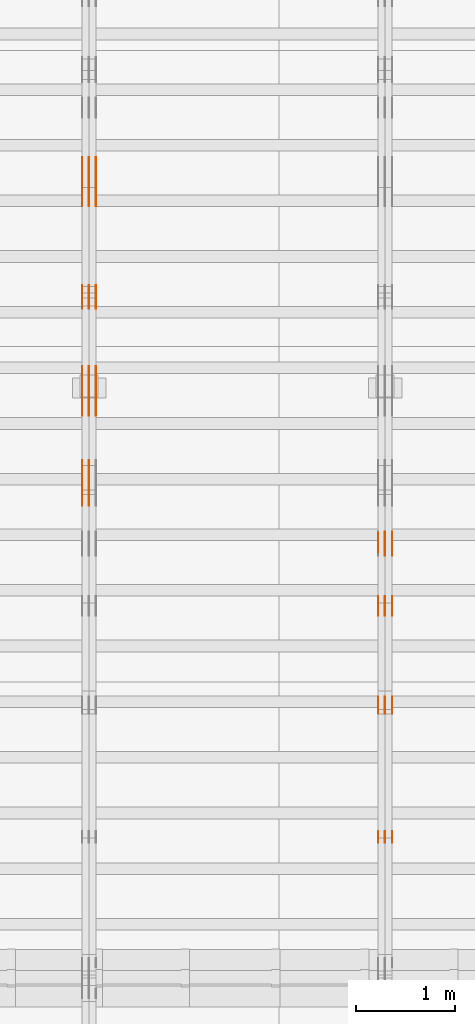
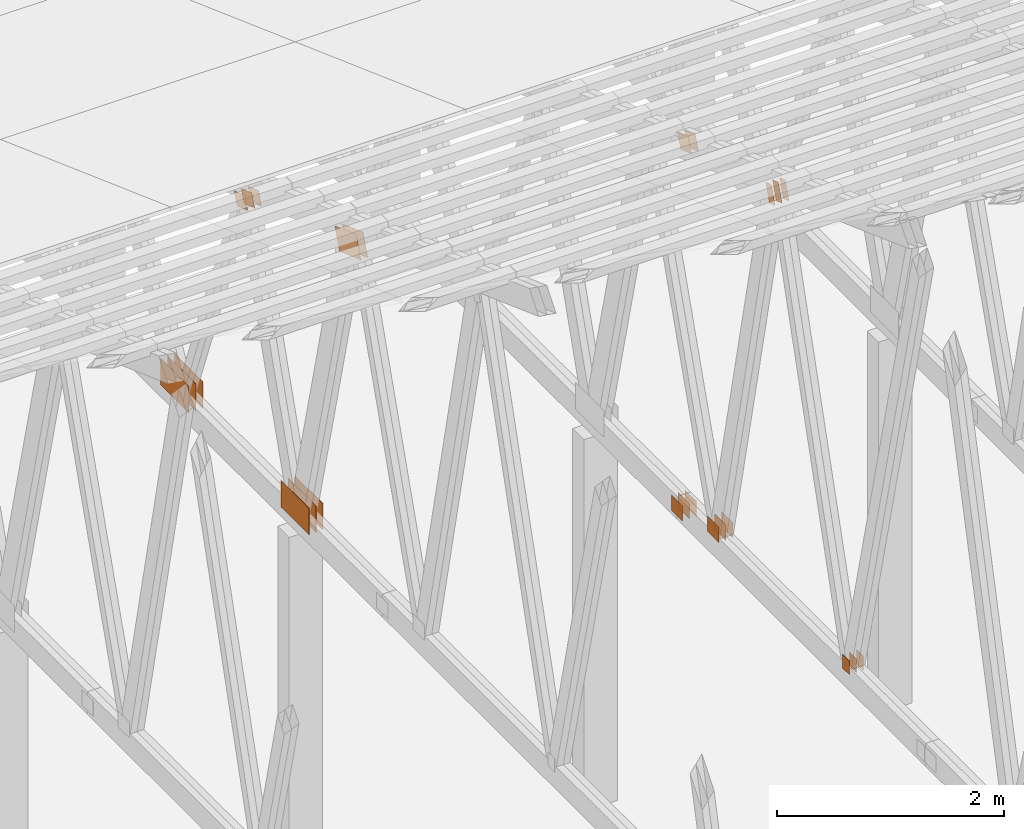
# One storey, part 122 of 189: 32 proxies.
"""IFC2X3 building model written with IfcOpenShell, lengths in millimetres."""

import ifcopenshell
import ifcopenshell.guid

model = None  # the IFC model being written
_history = None  # IfcOwnerHistory: only IFC2X3 demands one
_inside = {}  # id of a spatial element -> (the spatial element, [elements in it])
_under = {}  # id of a project, library or spatial element -> (it, [spatial elements below it])
_declared = {}  # id of a project -> (the project, [libraries it declares])
_typed = {}  # id of a type object -> (the type object, [elements of that type])
_made_of = {}  # id of a material, layer set ... -> (it, [elements and type objects made of it])


def new_model(schema):
    """Start an empty IFC model of exactly this schema.

    Asked for "IFC4X3", IfcOpenShell would pick the latest addendum, in which some entities
    have other attributes; the version numbers below select the first issue.
    IFC2X3 requires an IfcOwnerHistory on every rooted entity: one is made here for all.
    """
    global model, _history
    if schema == "IFC4X3":
        model = ifcopenshell.file(schema_version=(4, 3, 0, 0))
    else:
        model = ifcopenshell.file(schema=schema)
    _inside.clear()
    _under.clear()
    _declared.clear()
    _typed.clear()
    _made_of.clear()
    _history = None
    if model.schema == "IFC2X3":
        org = make("IfcOrganization", Name="unknown")
        user = make(
            "IfcPersonAndOrganization",
            ThePerson=make("IfcPerson", FamilyName="unknown"),
            TheOrganization=org,
        )
        app = make(
            "IfcApplication",
            ApplicationDeveloper=org,
            Version="unknown",
            ApplicationFullName="unknown",
            ApplicationIdentifier="unknown",
        )
        _history = make(
            "IfcOwnerHistory",
            OwningUser=user,
            OwningApplication=app,
            ChangeAction="ADDED",
            CreationDate=0,
        )
    return model


def make(cls, **values):
    """One entity of the class cls with the attributes given. An attribute that is None is left unset."""
    return model.create_entity(
        cls, **{name: value for name, value in values.items() if value is not None}
    )


def entity(cls, *values):
    """Any entity or typed value of the class cls, its attributes in the order of the schema. None: left unset."""
    e = model.create_entity(cls)
    for i, value in enumerate(values):
        if value is not None:
            e[i] = value
    return e


def rooted(cls, **values):
    """An entity with a GlobalId (a new one), such as an element, a storey or a relation."""
    return make(cls, GlobalId=ifcopenshell.guid.new(), OwnerHistory=_history, **values)


def si_unit(unit_type, name, prefix=None):
    """IfcSIUnit, for example si_unit("LENGTHUNIT", "METRE", prefix="MILLI")."""
    return make("IfcSIUnit", UnitType=unit_type, Prefix=prefix, Name=name)


def converted_unit(unit_type, name, factor, base, dimensions=None, offset=None):
    """IfcConversionBasedUnit, such as the inch: factor (a typed value) times the base unit."""
    return make(
        "IfcConversionBasedUnit"
        if offset is None
        else "IfcConversionBasedUnitWithOffset",
        ConversionOffset=offset,
        Dimensions=None
        if dimensions is None
        else entity("IfcDimensionalExponents", *dimensions),
        UnitType=unit_type,
        Name=name,
        ConversionFactor=make(
            "IfcMeasureWithUnit", ValueComponent=factor, UnitComponent=base
        ),
    )


def derived_unit(unit_type, elements):
    """IfcDerivedUnit: a product of units, each with its exponent."""
    return make(
        "IfcDerivedUnit",
        Elements=[
            make("IfcDerivedUnitElement", Unit=unit, Exponent=power)
            for unit, power in elements
        ],
        UnitType=unit_type,
    )


def assignment(units):
    """IfcUnitAssignment: the units of a project."""
    return None if units is None else make("IfcUnitAssignment", Units=units)


def point(xyz):
    """IfcCartesianPoint."""
    return None if xyz is None else make("IfcCartesianPoint", Coordinates=xyz)


def direction(xyz):
    """IfcDirection."""
    return None if xyz is None else make("IfcDirection", DirectionRatios=xyz)


def frame(location, z_axis=None, x_axis=None):
    """IfcAxis2Placement3D, a coordinate frame: its origin and axes. An axis left out is left unset."""
    return make(
        "IfcAxis2Placement3D",
        Location=point(location),
        Axis=direction(z_axis),
        RefDirection=direction(x_axis),
    )


def frame_2d(location, x_axis=None):
    """IfcAxis2Placement2D, a coordinate frame in the plane: its origin and x axis."""
    return make(
        "IfcAxis2Placement2D", Location=point(location), RefDirection=direction(x_axis)
    )


def origin():
    """The frame at (0, 0, 0) with its axes left unset."""
    return frame((0.0, 0.0, 0.0))


def origin_2d_with_axis():
    """The frame at (0, 0) in the plane with the x axis (1, 0) written out."""
    return frame_2d((0.0, 0.0), x_axis=(1.0, 0.0))


def place(relative_to, where):
    """IfcLocalPlacement: puts the frame where relative to a parent placement (None: the world)."""
    return make(
        "IfcLocalPlacement", PlacementRelTo=relative_to, RelativePlacement=where
    )


def context(
    kind, dimensions, precision=None, world=None, true_north=None, identifier=None
):
    """IfcGeometricRepresentationContext, for example the 3D "Model" context."""
    return make(
        "IfcGeometricRepresentationContext",
        ContextIdentifier=identifier,
        ContextType=kind,
        CoordinateSpaceDimension=dimensions,
        Precision=precision,
        WorldCoordinateSystem=world,
        TrueNorth=true_north,
    )


def subcontext(parent, identifier, kind, view, scale=None):
    """IfcGeometricRepresentationSubContext, for example "Body" below "Model"."""
    return make(
        "IfcGeometricRepresentationSubContext",
        ContextIdentifier=identifier,
        ContextType=kind,
        ParentContext=parent,
        TargetScale=scale,
        TargetView=view,
    )


def project(units=None, contexts=None):
    """IfcProject with its units and contexts."""
    return rooted(
        "IfcProject",
        Name="project",
        RepresentationContexts=contexts,
        UnitsInContext=assignment(units),
    )


def spatial(cls, under=None, at=None, **own):
    """A site, building, storey or space (cls), placed at a placement, below another one or the project."""
    s = rooted(cls, ObjectPlacement=at, **own)
    if under is not None:
        _under.setdefault(under.id(), (under, []))[1].append(s)
    return s


def polyline(points):
    """IfcPolyline through the points."""
    return make("IfcPolyline", Points=[point(p) for p in points])


def profile(cls, at=None, kind="AREA", **sizes):
    """A parametric profile (cls). Its sizes go by their IFC names, for example OverallWidth=200.0."""
    return make(cls, ProfileType=kind, Position=at, **sizes)


def rectangle(**sizes):
    """IfcRectangleProfileDef."""
    return profile("IfcRectangleProfileDef", **sizes)


def outline(outer, holes=None, kind="AREA"):
    """IfcArbitraryClosedProfileDef: a profile drawn as a closed curve; with holes, ...WithVoids."""
    if holes is None:
        return make("IfcArbitraryClosedProfileDef", ProfileType=kind, OuterCurve=outer)
    return make(
        "IfcArbitraryProfileDefWithVoids",
        ProfileType=kind,
        OuterCurve=outer,
        InnerCurves=holes,
    )


def extrude(swept, where, along, depth):
    """IfcExtrudedAreaSolid: the profile swept, set in the frame where, extruded along a direction by depth."""
    return make(
        "IfcExtrudedAreaSolid",
        SweptArea=swept,
        Position=where,
        ExtrudedDirection=direction(along),
        Depth=depth,
    )


def shape(context_of_items, identifier, shape_type, items):
    """IfcShapeRepresentation: the items that make up one representation, for example the "Body"."""
    return make(
        "IfcShapeRepresentation",
        ContextOfItems=context_of_items,
        RepresentationIdentifier=identifier,
        RepresentationType=shape_type,
        Items=items,
    )


def source(mapping_origin, context_of_items, identifier, shape_type, items):
    """IfcRepresentationMap: a shape defined once, which mapped items show again and again."""
    return make(
        "IfcRepresentationMap",
        MappingOrigin=mapping_origin,
        MappedRepresentation=shape(context_of_items, identifier, shape_type, items),
    )


def transform(
    local_origin,
    x_axis=None,
    y_axis=None,
    z_axis=None,
    scale=None,
    scale2=None,
    scale3=None,
    uniform=True,
):
    """IfcCartesianTransformationOperator3D, or its non-uniform kind. x_axis, y_axis, z_axis: its Axis1, 2, 3."""
    if uniform:
        return make(
            "IfcCartesianTransformationOperator3D",
            Axis1=direction(x_axis),
            Axis2=direction(y_axis),
            LocalOrigin=point(local_origin),
            Scale=scale,
            Axis3=direction(z_axis),
        )
    return make(
        "IfcCartesianTransformationOperator3DnonUniform",
        Axis1=direction(x_axis),
        Axis2=direction(y_axis),
        LocalOrigin=point(local_origin),
        Scale=scale,
        Axis3=direction(z_axis),
        Scale2=scale2,
        Scale3=scale3,
    )


def mapped(mapping_source, mapping_target):
    """IfcMappedItem: shows the shape of a source again, moved by a transform."""
    return make(
        "IfcMappedItem", MappingSource=mapping_source, MappingTarget=mapping_target
    )


def material(Name=None, Category=None):
    """IfcMaterial."""
    return make("IfcMaterial", Name=Name, Category=Category)


def made_of(thing, what):
    """Note that an element or type object is made of a material, layer set ...; save() writes the relation."""
    if what is not None:
        _made_of.setdefault(what.id(), (what, []))[1].append(thing)
    return thing


def type_object(cls, material=None, **own):
    """A type object (cls), such as IfcWallType, which elements share."""
    return made_of(rooted(cls, **own), material)


def type_shapes(of_type, sources):
    """Give a type object the sources (RepresentationMaps) that its elements show as mapped items."""
    of_type.RepresentationMaps = sources


def element(
    cls,
    number,
    at=None,
    inside=None,
    cuts=None,
    type_object=None,
    material=None,
    context=None,
    identifier="Body",
    shape_type=None,
    held_by="IfcProductDefinitionShape",
    body=None,
    shapes=None,
    **own,
):
    """One element of the class cls, such as IfcWall. Its Tag is "e" and its number.

    at: its placement. inside: the storey or other place that contains it. cuts: it is an
    opening in that element (IfcRelVoidsElement). A single representation is given by context,
    identifier, shape_type and body (its items); several are given by shapes. held_by: the class
    of the entity that holds the representations. save() writes the other relations.
    """
    e = rooted(cls, Tag="e%d" % number, ObjectPlacement=at, **own)
    if body is not None:
        shapes = [shape(context, identifier, shape_type, body)]
    if shapes is not None:
        e.Representation = make(held_by, Representations=shapes)
    if inside is not None:
        _inside.setdefault(inside.id(), (inside, []))[1].append(e)
    if cuts is not None:
        rooted(
            "IfcRelVoidsElement", RelatingBuildingElement=cuts, RelatedOpeningElement=e
        )
    if type_object is not None:
        _typed.setdefault(type_object.id(), (type_object, []))[1].append(e)
    return made_of(e, material)


def aggregate(whole, parts):
    """IfcRelAggregates: a whole, such as a stair, and the parts it consists of."""
    return rooted("IfcRelAggregates", RelatingObject=whole, RelatedObjects=parts)


def save(model, path):
    """Write the relations noted so far, then the file.

    IfcRelAggregates (storeys below a building ...), IfcRelContainedInSpatialStructure (elements
    in a storey), IfcRelDefinesByType, IfcRelAssociatesMaterial and IfcRelDeclares: one each for
    every whole, place, type object, material and project.
    """
    for whole, parts in _under.values():
        aggregate(whole, parts)
    for where, things in _inside.values():
        rooted(
            "IfcRelContainedInSpatialStructure",
            RelatedElements=things,
            RelatingStructure=where,
        )
    for kind, things in _typed.values():
        rooted("IfcRelDefinesByType", RelatedObjects=things, RelatingType=kind)
    for what, things in _made_of.values():
        rooted("IfcRelAssociatesMaterial", RelatedObjects=things, RelatingMaterial=what)
    for by, libraries in _declared.values():
        rooted("IfcRelDeclares", RelatingContext=by, RelatedDefinitions=libraries)
    model.write(path)


model = new_model("IFC2X3")

# Units and contexts
model_context = context("Model", 3, precision=0.01, world=origin(), true_north=direction((6.12303176911189e-17, 1.0)))
body_context = subcontext(model_context, "Body", "Model", "MODEL_VIEW")
ifc_project = project(units=[si_unit("LENGTHUNIT", "METRE", prefix="MILLI"), si_unit("AREAUNIT", "SQUARE_METRE"), si_unit("VOLUMEUNIT", "CUBIC_METRE"), converted_unit("PLANEANGLEUNIT", "DEGREE", entity("IfcRatioMeasure", 0.0174532925199433), si_unit("PLANEANGLEUNIT", "RADIAN"), dimensions=[0, 0, 0, 0, 0, 0, 0]), si_unit("MASSUNIT", "GRAM", prefix="KILO"), derived_unit("MASSDENSITYUNIT", [(si_unit("MASSUNIT", "GRAM", prefix="KILO"), 1), (si_unit("LENGTHUNIT", "METRE"), -3)]), si_unit("TIMEUNIT", "SECOND"), si_unit("FREQUENCYUNIT", "HERTZ"), si_unit("THERMODYNAMICTEMPERATUREUNIT", "DEGREE_CELSIUS"), derived_unit("THERMALTRANSMITTANCEUNIT", [(si_unit("MASSUNIT", "GRAM", prefix="KILO"), 1), (si_unit("THERMODYNAMICTEMPERATUREUNIT", "KELVIN"), -1), (si_unit("TIMEUNIT", "SECOND"), -3)]), derived_unit("VOLUMETRICFLOWRATEUNIT", [(si_unit("LENGTHUNIT", "METRE"), 3), (si_unit("TIMEUNIT", "SECOND"), -1)]), si_unit("ELECTRICCURRENTUNIT", "AMPERE"), si_unit("ELECTRICVOLTAGEUNIT", "VOLT"), si_unit("POWERUNIT", "WATT"), si_unit("FORCEUNIT", "NEWTON"), si_unit("ILLUMINANCEUNIT", "LUX"), si_unit("LUMINOUSFLUXUNIT", "LUMEN"), si_unit("LUMINOUSINTENSITYUNIT", "CANDELA"), derived_unit("USERDEFINED", [(si_unit("MASSUNIT", "GRAM", prefix="KILO"), -1), (si_unit("LENGTHUNIT", "METRE"), -2), (si_unit("TIMEUNIT", "SECOND"), 3), (si_unit("LUMINOUSFLUXUNIT", "LUMEN"), 1)]), derived_unit("LINEARVELOCITYUNIT", [(si_unit("LENGTHUNIT", "METRE"), 1), (si_unit("TIMEUNIT", "SECOND"), -1)]), si_unit("PRESSUREUNIT", "PASCAL"), derived_unit("USERDEFINED", [(si_unit("LENGTHUNIT", "METRE"), -2), (si_unit("MASSUNIT", "GRAM", prefix="KILO"), 1), (si_unit("TIMEUNIT", "SECOND"), -2)])], contexts=[model_context])

# Site, building, storey
site_placement = place(None, origin())
site = spatial("IfcSite", under=ifc_project, at=site_placement, CompositionType="ELEMENT")
building_placement = place(site_placement, origin())
building = spatial("IfcBuilding", under=site, at=building_placement, CompositionType="ELEMENT")
storey_placement = place(building_placement, origin())
storey = spatial("IfcBuildingStorey", under=building, at=storey_placement, Name="Default", CompositionType="ELEMENT", Elevation=0.0)

# Proxies
ifc_material_1 = material(Name="IfcSurfaceStyle #141706")
building_element_proxy_type_1 = type_object("IfcBuildingElementProxyType", PredefinedType="NOTDEFINED", material=ifc_material_1)
shared_shape_1 = source(origin(), body_context, "Body", "SweptSolid", [
    extrude(rectangle(XDim=150.0, YDim=120.0, at=origin_2d_with_axis()), frame((75.0, 60.0, 0.0), z_axis=(0.0, 0.0, 1.0), x_axis=(-1.0, 0.0, 0.0)), (0.0, 0.0, 1.0), 1.3),
])
type_shapes(building_element_proxy_type_1, [shared_shape_1])
proxy_1_placement = place(building_placement, frame((24301.3, 16120.724609375, 170.0), z_axis=(-1.0, 0.0, 0.0), x_axis=(0.0, 0.0, 1.0)))
element("IfcBuildingElementProxy", 1, at=proxy_1_placement, inside=storey, type_object=building_element_proxy_type_1, material=ifc_material_1, context=body_context, shape_type="MappedRepresentation", body=[
    mapped(shared_shape_1, transform((0.0, 0.0, 0.0), scale=1.0)),
])
ifc_material_2 = material(Name="IfcSurfaceStyle #141649")
building_element_proxy_type_2 = type_object("IfcBuildingElementProxyType", PredefinedType="NOTDEFINED", material=ifc_material_2)
shared_shape_2 = source(origin(), body_context, "Body", "SweptSolid", [
    extrude(rectangle(XDim=150.0, YDim=120.0, at=origin_2d_with_axis()), frame((75.0, 60.0, 0.0), z_axis=(0.0, 0.0, 1.0), x_axis=(-1.0, 0.0, 0.0)), (0.0, 0.0, 1.0), 1.29999999999999),
])
type_shapes(building_element_proxy_type_2, [shared_shape_2])
proxy_2_placement = place(building_placement, frame((24230.0, 16120.724609375, 170.0), z_axis=(-1.0, 0.0, 0.0), x_axis=(0.0, 0.0, 1.0)))
element("IfcBuildingElementProxy", 2, at=proxy_2_placement, inside=storey, type_object=building_element_proxy_type_2, material=ifc_material_2, context=body_context, shape_type="MappedRepresentation", body=[
    mapped(shared_shape_2, transform((0.0, 0.0, 0.0), scale=1.0)),
])
ifc_material_3 = material(Name="IfcSurfaceStyle #141592")
building_element_proxy_type_3 = type_object("IfcBuildingElementProxyType", PredefinedType="NOTDEFINED", material=ifc_material_3)
shared_shape_3 = source(origin(), body_context, "Body", "SweptSolid", [
    extrude(rectangle(XDim=150.0, YDim=120.0, at=origin_2d_with_axis()), frame((75.0, 60.0, 0.0), z_axis=(0.0, 0.0, 1.0), x_axis=(-1.0, 0.0, 0.0)), (0.0, 0.0, 1.0), 1.29999999999999),
])
type_shapes(building_element_proxy_type_3, [shared_shape_3])
proxy_3_placement = place(building_placement, frame((24231.3, 16120.724609375, 170.0), z_axis=(-1.0, 0.0, 0.0), x_axis=(0.0, 0.0, 1.0)))
element("IfcBuildingElementProxy", 3, at=proxy_3_placement, inside=storey, type_object=building_element_proxy_type_3, material=ifc_material_3, context=body_context, shape_type="MappedRepresentation", body=[
    mapped(shared_shape_3, transform((0.0, 0.0, 0.0), scale=1.0)),
])
ifc_material_4 = material(Name="IfcSurfaceStyle #141535")
building_element_proxy_type_4 = type_object("IfcBuildingElementProxyType", PredefinedType="NOTDEFINED", material=ifc_material_4)
shared_shape_4 = source(origin(), body_context, "Body", "SweptSolid", [
    extrude(rectangle(XDim=150.0, YDim=120.0, at=origin_2d_with_axis()), frame((75.0, 60.0, 0.0), z_axis=(0.0, 0.0, 1.0), x_axis=(-1.0, 0.0, 0.0)), (0.0, 0.0, 1.0), 1.29999999999999),
])
type_shapes(building_element_proxy_type_4, [shared_shape_4])
proxy_4_placement = place(building_placement, frame((24160.0, 16120.724609375, 170.0), z_axis=(-1.0, 0.0, 0.0), x_axis=(0.0, 0.0, 1.0)))
element("IfcBuildingElementProxy", 4, at=proxy_4_placement, inside=storey, type_object=building_element_proxy_type_4, material=ifc_material_4, context=body_context, shape_type="MappedRepresentation", body=[
    mapped(shared_shape_4, transform((0.0, 0.0, 0.0), scale=1.0)),
])
ifc_material_5 = material(Name="IfcSurfaceStyle #140566")
building_element_proxy_type_5 = type_object("IfcBuildingElementProxyType", PredefinedType="NOTDEFINED", material=ifc_material_5)
shared_shape_5 = source(origin(), body_context, "Body", "SweptSolid", [
    extrude(outline(polyline([(-99.9998320329903, -54.0001530266309), (99.9998809717702, -54.0001530266309), (100.000228452157, 54.0001530266309), (-100.000277390937, 54.0001530266309), (-99.9998320329903, -54.0001530266309)])), frame((100.000228452157, 54.0002543377796, 0.0), z_axis=(0.0, 0.0, 1.0), x_axis=(-1.0, 0.0, 0.0)), (0.0, 0.0, 1.0), 1.3),
])
type_shapes(building_element_proxy_type_5, [shared_shape_5])
proxy_5_placement = place(building_placement, frame((24301.3, 17599.4482421875, 4577.14111328125), z_axis=(-1.0, 0.0, 0.0), x_axis=(0.0, -0.342020143325669, -0.939692620785908)))
element("IfcBuildingElementProxy", 5, at=proxy_5_placement, inside=storey, type_object=building_element_proxy_type_5, material=ifc_material_5, context=body_context, shape_type="MappedRepresentation", body=[
    mapped(shared_shape_5, transform((0.0, 0.0, 0.0), scale=1.0)),
])
ifc_material_6 = material(Name="IfcSurfaceStyle #140509")
building_element_proxy_type_6 = type_object("IfcBuildingElementProxyType", PredefinedType="NOTDEFINED", material=ifc_material_6)
shared_shape_6 = source(origin(), body_context, "Body", "SweptSolid", [
    extrude(outline(polyline([(-99.9998320329903, -54.0001530266309), (99.9998809717702, -54.0001530266309), (100.000228452157, 54.0001530266309), (-100.000277390937, 54.0001530266309), (-99.9998320329903, -54.0001530266309)])), frame((100.000228452157, 54.0002543377796, 0.0), z_axis=(0.0, 0.0, 1.0), x_axis=(-1.0, 0.0, 0.0)), (0.0, 0.0, 1.0), 1.29999999999998),
])
type_shapes(building_element_proxy_type_6, [shared_shape_6])
proxy_6_placement = place(building_placement, frame((24230.0, 17599.4482421875, 4577.14111328125), z_axis=(-1.0, 0.0, 0.0), x_axis=(0.0, -0.342020143325669, -0.939692620785908)))
element("IfcBuildingElementProxy", 6, at=proxy_6_placement, inside=storey, type_object=building_element_proxy_type_6, material=ifc_material_6, context=body_context, shape_type="MappedRepresentation", body=[
    mapped(shared_shape_6, transform((0.0, 0.0, 0.0), scale=1.0)),
])
ifc_material_7 = material(Name="IfcSurfaceStyle #140452")
building_element_proxy_type_7 = type_object("IfcBuildingElementProxyType", PredefinedType="NOTDEFINED", material=ifc_material_7)
shared_shape_7 = source(origin(), body_context, "Body", "SweptSolid", [
    extrude(outline(polyline([(-99.9998320329903, -54.0001530266309), (99.9998809717702, -54.0001530266309), (100.000228452157, 54.0001530266309), (-100.000277390937, 54.0001530266309), (-99.9998320329903, -54.0001530266309)])), frame((100.000228452157, 54.0002543377796, 0.0), z_axis=(0.0, 0.0, 1.0), x_axis=(-1.0, 0.0, 0.0)), (0.0, 0.0, 1.0), 1.29999999999998),
])
type_shapes(building_element_proxy_type_7, [shared_shape_7])
proxy_7_placement = place(building_placement, frame((24231.3, 17599.4482421875, 4577.14111328125), z_axis=(-1.0, 0.0, 0.0), x_axis=(0.0, -0.342020143325669, -0.939692620785908)))
element("IfcBuildingElementProxy", 7, at=proxy_7_placement, inside=storey, type_object=building_element_proxy_type_7, material=ifc_material_7, context=body_context, shape_type="MappedRepresentation", body=[
    mapped(shared_shape_7, transform((0.0, 0.0, 0.0), scale=1.0)),
])
ifc_material_8 = material(Name="IfcSurfaceStyle #140395")
building_element_proxy_type_8 = type_object("IfcBuildingElementProxyType", PredefinedType="NOTDEFINED", material=ifc_material_8)
shared_shape_8 = source(origin(), body_context, "Body", "SweptSolid", [
    extrude(outline(polyline([(-99.9998320329903, -54.0001530266309), (99.9998809717702, -54.0001530266309), (100.000228452157, 54.0001530266309), (-100.000277390937, 54.0001530266309), (-99.9998320329903, -54.0001530266309)])), frame((100.000228452157, 54.0002543377796, 0.0), z_axis=(0.0, 0.0, 1.0), x_axis=(-1.0, 0.0, 0.0)), (0.0, 0.0, 1.0), 1.29999999999999),
])
type_shapes(building_element_proxy_type_8, [shared_shape_8])
proxy_8_placement = place(building_placement, frame((24160.0, 17599.4482421875, 4577.14111328125), z_axis=(-1.0, 0.0, 0.0), x_axis=(0.0, -0.342020143325669, -0.939692620785908)))
element("IfcBuildingElementProxy", 8, at=proxy_8_placement, inside=storey, type_object=building_element_proxy_type_8, material=ifc_material_8, context=body_context, shape_type="MappedRepresentation", body=[
    mapped(shared_shape_8, transform((0.0, 0.0, 0.0), scale=1.0)),
])
ifc_material_9 = material(Name="IfcSurfaceStyle #140338")
building_element_proxy_type_9 = type_object("IfcBuildingElementProxyType", PredefinedType="NOTDEFINED", material=ifc_material_9)
shared_shape_9 = source(origin(), body_context, "Body", "SweptSolid", [
    extrude(rectangle(XDim=200.0, YDim=168.0, at=origin_2d_with_axis()), frame((100.0, 84.0, 0.0), z_axis=(0.0, 0.0, 1.0), x_axis=(-1.0, 0.0, 0.0)), (0.0, 0.0, 1.0), 1.3),
])
type_shapes(building_element_proxy_type_9, [shared_shape_9])
proxy_9_placement = place(building_placement, frame((24301.3, 18619.8427734375, 197.0), z_axis=(-1.0, 0.0, 0.0), x_axis=(0.0, -1.0, 0.0)))
element("IfcBuildingElementProxy", 9, at=proxy_9_placement, inside=storey, type_object=building_element_proxy_type_9, material=ifc_material_9, context=body_context, shape_type="MappedRepresentation", body=[
    mapped(shared_shape_9, transform((0.0, 0.0, 0.0), scale=1.0)),
])
ifc_material_10 = material(Name="IfcSurfaceStyle #140281")
building_element_proxy_type_10 = type_object("IfcBuildingElementProxyType", PredefinedType="NOTDEFINED", material=ifc_material_10)
shared_shape_10 = source(origin(), body_context, "Body", "SweptSolid", [
    extrude(rectangle(XDim=200.0, YDim=168.0, at=origin_2d_with_axis()), frame((100.0, 84.0, 0.0), z_axis=(0.0, 0.0, 1.0), x_axis=(-1.0, 0.0, 0.0)), (0.0, 0.0, 1.0), 1.29999999999998),
])
type_shapes(building_element_proxy_type_10, [shared_shape_10])
proxy_10_placement = place(building_placement, frame((24230.0, 18619.8427734375, 197.0), z_axis=(-1.0, 0.0, 0.0), x_axis=(0.0, -1.0, 0.0)))
element("IfcBuildingElementProxy", 10, at=proxy_10_placement, inside=storey, type_object=building_element_proxy_type_10, material=ifc_material_10, context=body_context, shape_type="MappedRepresentation", body=[
    mapped(shared_shape_10, transform((0.0, 0.0, 0.0), scale=1.0)),
])
ifc_material_11 = material(Name="IfcSurfaceStyle #140224")
building_element_proxy_type_11 = type_object("IfcBuildingElementProxyType", PredefinedType="NOTDEFINED", material=ifc_material_11)
shared_shape_11 = source(origin(), body_context, "Body", "SweptSolid", [
    extrude(rectangle(XDim=200.0, YDim=168.0, at=origin_2d_with_axis()), frame((100.0, 84.0, 0.0), z_axis=(0.0, 0.0, 1.0), x_axis=(-1.0, 0.0, 0.0)), (0.0, 0.0, 1.0), 1.29999999999998),
])
type_shapes(building_element_proxy_type_11, [shared_shape_11])
proxy_11_placement = place(building_placement, frame((24231.3, 18619.8427734375, 197.0), z_axis=(-1.0, 0.0, 0.0), x_axis=(0.0, -1.0, 0.0)))
element("IfcBuildingElementProxy", 11, at=proxy_11_placement, inside=storey, type_object=building_element_proxy_type_11, material=ifc_material_11, context=body_context, shape_type="MappedRepresentation", body=[
    mapped(shared_shape_11, transform((0.0, 0.0, 0.0), scale=1.0)),
])
ifc_material_12 = material(Name="IfcSurfaceStyle #140167")
building_element_proxy_type_12 = type_object("IfcBuildingElementProxyType", PredefinedType="NOTDEFINED", material=ifc_material_12)
shared_shape_12 = source(origin(), body_context, "Body", "SweptSolid", [
    extrude(rectangle(XDim=200.0, YDim=168.0, at=origin_2d_with_axis()), frame((100.0, 84.0, 0.0), z_axis=(0.0, 0.0, 1.0), x_axis=(-1.0, 0.0, 0.0)), (0.0, 0.0, 1.0), 1.29999999999999),
])
type_shapes(building_element_proxy_type_12, [shared_shape_12])
proxy_12_placement = place(building_placement, frame((24160.0, 18619.8427734375, 197.0), z_axis=(-1.0, 0.0, 0.0), x_axis=(0.0, -1.0, 0.0)))
element("IfcBuildingElementProxy", 12, at=proxy_12_placement, inside=storey, type_object=building_element_proxy_type_12, material=ifc_material_12, context=body_context, shape_type="MappedRepresentation", body=[
    mapped(shared_shape_12, transform((0.0, 0.0, 0.0), scale=1.0)),
])
ifc_material_13 = material(Name="IfcSurfaceStyle #134410")
building_element_proxy_type_13 = type_object("IfcBuildingElementProxyType", PredefinedType="NOTDEFINED", material=ifc_material_13)
shared_shape_13 = source(origin(), body_context, "Body", "SweptSolid", [
    extrude(rectangle(XDim=200.0, YDim=168.0, at=origin_2d_with_axis()), frame((100.0, 84.0, 0.0), z_axis=(0.0, 0.0, 1.0), x_axis=(-1.0, 0.0, 0.0)), (0.0, 0.0, 1.0), 1.3),
])
type_shapes(building_element_proxy_type_13, [shared_shape_13])
proxy_13_placement = place(building_placement, frame((24301.3, 19061.7587890625, 206.5), z_axis=(-1.0, 0.0, 0.0), x_axis=(0.0, 1.0, 0.0)))
element("IfcBuildingElementProxy", 13, at=proxy_13_placement, inside=storey, type_object=building_element_proxy_type_13, material=ifc_material_13, context=body_context, shape_type="MappedRepresentation", body=[
    mapped(shared_shape_13, transform((0.0, 0.0, 0.0), scale=1.0)),
])
ifc_material_14 = material(Name="IfcSurfaceStyle #134353")
building_element_proxy_type_14 = type_object("IfcBuildingElementProxyType", PredefinedType="NOTDEFINED", material=ifc_material_14)
shared_shape_14 = source(origin(), body_context, "Body", "SweptSolid", [
    extrude(rectangle(XDim=200.0, YDim=168.0, at=origin_2d_with_axis()), frame((100.0, 84.0, 0.0), z_axis=(0.0, 0.0, 1.0), x_axis=(-1.0, 0.0, 0.0)), (0.0, 0.0, 1.0), 1.29999999999998),
])
type_shapes(building_element_proxy_type_14, [shared_shape_14])
proxy_14_placement = place(building_placement, frame((24230.0, 19061.7587890625, 206.5), z_axis=(-1.0, 0.0, 0.0), x_axis=(0.0, 1.0, 0.0)))
element("IfcBuildingElementProxy", 14, at=proxy_14_placement, inside=storey, type_object=building_element_proxy_type_14, material=ifc_material_14, context=body_context, shape_type="MappedRepresentation", body=[
    mapped(shared_shape_14, transform((0.0, 0.0, 0.0), scale=1.0)),
])
ifc_material_15 = material(Name="IfcSurfaceStyle #134296")
building_element_proxy_type_15 = type_object("IfcBuildingElementProxyType", PredefinedType="NOTDEFINED", material=ifc_material_15)
shared_shape_15 = source(origin(), body_context, "Body", "SweptSolid", [
    extrude(rectangle(XDim=200.0, YDim=168.0, at=origin_2d_with_axis()), frame((100.0, 84.0, 0.0), z_axis=(0.0, 0.0, 1.0), x_axis=(-1.0, 0.0, 0.0)), (0.0, 0.0, 1.0), 1.29999999999998),
])
type_shapes(building_element_proxy_type_15, [shared_shape_15])
proxy_15_placement = place(building_placement, frame((24231.3, 19061.7587890625, 206.5), z_axis=(-1.0, 0.0, 0.0), x_axis=(0.0, 1.0, 0.0)))
element("IfcBuildingElementProxy", 15, at=proxy_15_placement, inside=storey, type_object=building_element_proxy_type_15, material=ifc_material_15, context=body_context, shape_type="MappedRepresentation", body=[
    mapped(shared_shape_15, transform((0.0, 0.0, 0.0), scale=1.0)),
])
ifc_material_16 = material(Name="IfcSurfaceStyle #134239")
building_element_proxy_type_16 = type_object("IfcBuildingElementProxyType", PredefinedType="NOTDEFINED", material=ifc_material_16)
shared_shape_16 = source(origin(), body_context, "Body", "SweptSolid", [
    extrude(rectangle(XDim=200.0, YDim=168.0, at=origin_2d_with_axis()), frame((100.0, 84.0, 0.0), z_axis=(0.0, 0.0, 1.0), x_axis=(-1.0, 0.0, 0.0)), (0.0, 0.0, 1.0), 1.29999999999999),
])
type_shapes(building_element_proxy_type_16, [shared_shape_16])
proxy_16_placement = place(building_placement, frame((24160.0, 19061.7587890625, 206.5), z_axis=(-1.0, 0.0, 0.0), x_axis=(0.0, 1.0, 0.0)))
element("IfcBuildingElementProxy", 16, at=proxy_16_placement, inside=storey, type_object=building_element_proxy_type_16, material=ifc_material_16, context=body_context, shape_type="MappedRepresentation", body=[
    mapped(shared_shape_16, transform((0.0, 0.0, 0.0), scale=1.0)),
])
ifc_material_17 = material(Name="IfcSurfaceStyle #132250")
building_element_proxy_type_17 = type_object("IfcBuildingElementProxyType", PredefinedType="NOTDEFINED", material=ifc_material_17)
shared_shape_17 = source(origin(), body_context, "Body", "SweptSolid", [
    extrude(outline(polyline([(-100.000115120732, -83.9999347094754), (99.9997648860521, -83.9999347094754), (100.000156871236, 83.9999347094753), (-99.9998066365565, 83.9999347094753), (-100.000115120732, -83.9999347094754)])), frame((100.000156871236, 84.0000502182443, 0.0), z_axis=(0.0, 0.0, 1.0), x_axis=(-1.0, 0.0, 0.0)), (0.0, 0.0, 1.0), 1.3),
])
type_shapes(building_element_proxy_type_17, [shared_shape_17])
proxy_17_placement = place(building_placement, frame((24301.3, 19216.0995831719, 3923.28093386695), z_axis=(-1.0, 0.0, 0.0), x_axis=(0.0, -0.939692620785908, 0.342020143325669)))
element("IfcBuildingElementProxy", 17, at=proxy_17_placement, inside=storey, type_object=building_element_proxy_type_17, material=ifc_material_17, context=body_context, shape_type="MappedRepresentation", body=[
    mapped(shared_shape_17, transform((0.0, 0.0, 0.0), scale=1.0)),
])
ifc_material_18 = material(Name="IfcSurfaceStyle #132193")
building_element_proxy_type_18 = type_object("IfcBuildingElementProxyType", PredefinedType="NOTDEFINED", material=ifc_material_18)
shared_shape_18 = source(origin(), body_context, "Body", "SweptSolid", [
    extrude(outline(polyline([(-100.000115120732, -83.9999347094754), (99.9997648860521, -83.9999347094754), (100.000156871236, 83.9999347094753), (-99.9998066365565, 83.9999347094753), (-100.000115120732, -83.9999347094754)])), frame((100.000156871236, 84.0000502182443, 0.0), z_axis=(0.0, 0.0, 1.0), x_axis=(-1.0, 0.0, 0.0)), (0.0, 0.0, 1.0), 1.29999999999998),
])
type_shapes(building_element_proxy_type_18, [shared_shape_18])
proxy_18_placement = place(building_placement, frame((24230.0, 19216.0995831719, 3923.28093386695), z_axis=(-1.0, 0.0, 0.0), x_axis=(0.0, -0.939692620785908, 0.342020143325669)))
element("IfcBuildingElementProxy", 18, at=proxy_18_placement, inside=storey, type_object=building_element_proxy_type_18, material=ifc_material_18, context=body_context, shape_type="MappedRepresentation", body=[
    mapped(shared_shape_18, transform((0.0, 0.0, 0.0), scale=1.0)),
])
ifc_material_19 = material(Name="IfcSurfaceStyle #123750")
building_element_proxy_type_19 = type_object("IfcBuildingElementProxyType", PredefinedType="NOTDEFINED", material=ifc_material_19)
shared_shape_19 = source(origin(), body_context, "Body", "SweptSolid", [
    extrude(outline(polyline([(-200.000344770935, -119.999765965113), (199.999582244654, -119.999765965113), (200.000344770935, 119.999765965113), (-199.999582244653, 119.999765965113), (-200.000344770935, -119.999765965113)])), frame((200.000344770935, 119.999990805307, 0.0), z_axis=(0.0, 0.0, 1.0), x_axis=(-1.0, 0.0, 0.0)), (0.0, 0.0, 1.0), 1.29999999999997),
])
type_shapes(building_element_proxy_type_19, [shared_shape_19])
proxy_19_placement = place(building_placement, frame((21231.3, 19620.1777846684, 3837.77137841443), z_axis=(-1.0, 0.0, 0.0), x_axis=(0.0, 0.939692620785908, -0.342020143325669)))
element("IfcBuildingElementProxy", 19, at=proxy_19_placement, inside=storey, type_object=building_element_proxy_type_19, material=ifc_material_19, context=body_context, shape_type="MappedRepresentation", body=[
    mapped(shared_shape_19, transform((0.0, 0.0, 0.0), scale=1.0)),
])
ifc_material_20 = material(Name="IfcSurfaceStyle #123693")
building_element_proxy_type_20 = type_object("IfcBuildingElementProxyType", PredefinedType="NOTDEFINED", material=ifc_material_20)
shared_shape_20 = source(origin(), body_context, "Body", "SweptSolid", [
    extrude(outline(polyline([(-200.000344770935, -119.999765965113), (199.999582244654, -119.999765965113), (200.000344770935, 119.999765965113), (-199.999582244653, 119.999765965113), (-200.000344770935, -119.999765965113)])), frame((200.000344770935, 119.999990805307, 0.0), z_axis=(0.0, 0.0, 1.0), x_axis=(-1.0, 0.0, 0.0)), (0.0, 0.0, 1.0), 1.29999999999998),
])
type_shapes(building_element_proxy_type_20, [shared_shape_20])
proxy_20_placement = place(building_placement, frame((21160.0, 19620.1777846684, 3837.77137841443), z_axis=(-1.0, 0.0, 0.0), x_axis=(0.0, 0.939692620785908, -0.342020143325669)))
element("IfcBuildingElementProxy", 20, at=proxy_20_placement, inside=storey, type_object=building_element_proxy_type_20, material=ifc_material_20, context=body_context, shape_type="MappedRepresentation", body=[
    mapped(shared_shape_20, transform((0.0, 0.0, 0.0), scale=1.0)),
])
ifc_material_21 = material(Name="IfcSurfaceStyle #123636")
building_element_proxy_type_21 = type_object("IfcBuildingElementProxyType", PredefinedType="NOTDEFINED", material=ifc_material_21)
shared_shape_21 = source(origin(), body_context, "Body", "SweptSolid", [
    extrude(rectangle(XDim=500.0, YDim=288.0, at=origin_2d_with_axis()), frame((250.0, 144.0, 0.0), z_axis=(0.0, 0.0, 1.0), x_axis=(-1.0, 0.0, 0.0)), (0.0, 0.0, 1.0), 1.29999999999998),
])
type_shapes(building_element_proxy_type_21, [shared_shape_21])
proxy_21_placement = place(building_placement, frame((21301.3, 20948.0908203125, 101.0), z_axis=(-1.0, 0.0, 0.0), x_axis=(0.0, -1.0, 0.0)))
element("IfcBuildingElementProxy", 21, at=proxy_21_placement, inside=storey, type_object=building_element_proxy_type_21, material=ifc_material_21, context=body_context, shape_type="MappedRepresentation", body=[
    mapped(shared_shape_21, transform((0.0, 0.0, 0.0), scale=1.0)),
])
ifc_material_22 = material(Name="IfcSurfaceStyle #123579")
building_element_proxy_type_22 = type_object("IfcBuildingElementProxyType", PredefinedType="NOTDEFINED", material=ifc_material_22)
shared_shape_22 = source(origin(), body_context, "Body", "SweptSolid", [
    extrude(rectangle(XDim=500.0, YDim=288.0, at=origin_2d_with_axis()), frame((250.0, 144.0, 0.0), z_axis=(0.0, 0.0, 1.0), x_axis=(-1.0, 0.0, 0.0)), (0.0, 0.0, 1.0), 1.29999999999997),
])
type_shapes(building_element_proxy_type_22, [shared_shape_22])
proxy_22_placement = place(building_placement, frame((21230.0, 20948.0908203125, 101.0), z_axis=(-1.0, 0.0, 0.0), x_axis=(0.0, -1.0, 0.0)))
element("IfcBuildingElementProxy", 22, at=proxy_22_placement, inside=storey, type_object=building_element_proxy_type_22, material=ifc_material_22, context=body_context, shape_type="MappedRepresentation", body=[
    mapped(shared_shape_22, transform((0.0, 0.0, 0.0), scale=1.0)),
])
ifc_material_23 = material(Name="IfcSurfaceStyle #123522")
building_element_proxy_type_23 = type_object("IfcBuildingElementProxyType", PredefinedType="NOTDEFINED", material=ifc_material_23)
shared_shape_23 = source(origin(), body_context, "Body", "SweptSolid", [
    extrude(rectangle(XDim=500.0, YDim=288.0, at=origin_2d_with_axis()), frame((250.0, 144.0, 0.0), z_axis=(0.0, 0.0, 1.0), x_axis=(-1.0, 0.0, 0.0)), (0.0, 0.0, 1.0), 1.29999999999997),
])
type_shapes(building_element_proxy_type_23, [shared_shape_23])
proxy_23_placement = place(building_placement, frame((21231.3, 20948.0908203125, 101.0), z_axis=(-1.0, 0.0, 0.0), x_axis=(0.0, -1.0, 0.0)))
element("IfcBuildingElementProxy", 23, at=proxy_23_placement, inside=storey, type_object=building_element_proxy_type_23, material=ifc_material_23, context=body_context, shape_type="MappedRepresentation", body=[
    mapped(shared_shape_23, transform((0.0, 0.0, 0.0), scale=1.0)),
])
ifc_material_24 = material(Name="IfcSurfaceStyle #123465")
building_element_proxy_type_24 = type_object("IfcBuildingElementProxyType", PredefinedType="NOTDEFINED", material=ifc_material_24)
shared_shape_24 = source(origin(), body_context, "Body", "SweptSolid", [
    extrude(rectangle(XDim=500.0, YDim=288.0, at=origin_2d_with_axis()), frame((250.0, 144.0, 0.0), z_axis=(0.0, 0.0, 1.0), x_axis=(-1.0, 0.0, 0.0)), (0.0, 0.0, 1.0), 1.29999999999997),
])
type_shapes(building_element_proxy_type_24, [shared_shape_24])
proxy_24_placement = place(building_placement, frame((21160.0, 20948.0908203125, 101.0), z_axis=(-1.0, 0.0, 0.0), x_axis=(0.0, -1.0, 0.0)))
element("IfcBuildingElementProxy", 24, at=proxy_24_placement, inside=storey, type_object=building_element_proxy_type_24, material=ifc_material_24, context=body_context, shape_type="MappedRepresentation", body=[
    mapped(shared_shape_24, transform((0.0, 0.0, 0.0), scale=1.0)),
])
ifc_material_25 = material(Name="IfcSurfaceStyle #122952")
building_element_proxy_type_25 = type_object("IfcBuildingElementProxyType", PredefinedType="NOTDEFINED", material=ifc_material_25)
shared_shape_25 = source(origin(), body_context, "Body", "SweptSolid", [
    extrude(outline(polyline([(-100.000279336925, -71.9999636698844), (100.000143005157, -71.9999636698844), (100.00004991978, 71.9999636698844), (-99.9999135880125, 71.9999636698845), (-100.000279336925, -71.9999636698844)])), frame((100.000143005157, 72.0001110824169, 0.0), z_axis=(0.0, 0.0, 1.0), x_axis=(-1.0, 0.0, 0.0)), (0.0, 0.0, 1.0), 1.3),
])
type_shapes(building_element_proxy_type_25, [shared_shape_25])
proxy_25_placement = place(building_placement, frame((21301.3, 21584.0819808932, 3071.51551466861), z_axis=(-1.0, 0.0, 0.0), x_axis=(0.0, 0.939692620785908, -0.342020143325669)))
element("IfcBuildingElementProxy", 25, at=proxy_25_placement, inside=storey, type_object=building_element_proxy_type_25, material=ifc_material_25, context=body_context, shape_type="MappedRepresentation", body=[
    mapped(shared_shape_25, transform((0.0, 0.0, 0.0), scale=1.0)),
])
ifc_material_26 = material(Name="IfcSurfaceStyle #122895")
building_element_proxy_type_26 = type_object("IfcBuildingElementProxyType", PredefinedType="NOTDEFINED", material=ifc_material_26)
shared_shape_26 = source(origin(), body_context, "Body", "SweptSolid", [
    extrude(outline(polyline([(-100.000279336925, -71.9999636698844), (100.000143005157, -71.9999636698844), (100.00004991978, 71.9999636698844), (-99.9999135880125, 71.9999636698845), (-100.000279336925, -71.9999636698844)])), frame((100.000143005157, 72.0001110824169, 0.0), z_axis=(0.0, 0.0, 1.0), x_axis=(-1.0, 0.0, 0.0)), (0.0, 0.0, 1.0), 1.29999999999998),
])
type_shapes(building_element_proxy_type_26, [shared_shape_26])
proxy_26_placement = place(building_placement, frame((21230.0, 21584.0819808932, 3071.51551466861), z_axis=(-1.0, 0.0, 0.0), x_axis=(0.0, 0.939692620785908, -0.342020143325669)))
element("IfcBuildingElementProxy", 26, at=proxy_26_placement, inside=storey, type_object=building_element_proxy_type_26, material=ifc_material_26, context=body_context, shape_type="MappedRepresentation", body=[
    mapped(shared_shape_26, transform((0.0, 0.0, 0.0), scale=1.0)),
])
ifc_material_27 = material(Name="IfcSurfaceStyle #122838")
building_element_proxy_type_27 = type_object("IfcBuildingElementProxyType", PredefinedType="NOTDEFINED", material=ifc_material_27)
shared_shape_27 = source(origin(), body_context, "Body", "SweptSolid", [
    extrude(outline(polyline([(-100.000279336925, -71.9999636698844), (100.000143005157, -71.9999636698844), (100.00004991978, 71.9999636698844), (-99.9999135880125, 71.9999636698845), (-100.000279336925, -71.9999636698844)])), frame((100.000143005157, 72.0001110824169, 0.0), z_axis=(0.0, 0.0, 1.0), x_axis=(-1.0, 0.0, 0.0)), (0.0, 0.0, 1.0), 1.29999999999998),
])
type_shapes(building_element_proxy_type_27, [shared_shape_27])
proxy_27_placement = place(building_placement, frame((21231.3, 21584.0819808932, 3071.51551466861), z_axis=(-1.0, 0.0, 0.0), x_axis=(0.0, 0.939692620785908, -0.342020143325669)))
element("IfcBuildingElementProxy", 27, at=proxy_27_placement, inside=storey, type_object=building_element_proxy_type_27, material=ifc_material_27, context=body_context, shape_type="MappedRepresentation", body=[
    mapped(shared_shape_27, transform((0.0, 0.0, 0.0), scale=1.0)),
])
ifc_material_28 = material(Name="IfcSurfaceStyle #122781")
building_element_proxy_type_28 = type_object("IfcBuildingElementProxyType", PredefinedType="NOTDEFINED", material=ifc_material_28)
shared_shape_28 = source(origin(), body_context, "Body", "SweptSolid", [
    extrude(outline(polyline([(-100.000279336925, -71.9999636698844), (100.000143005157, -71.9999636698844), (100.00004991978, 71.9999636698844), (-99.9999135880125, 71.9999636698845), (-100.000279336925, -71.9999636698844)])), frame((100.000143005157, 72.0001110824169, 0.0), z_axis=(0.0, 0.0, 1.0), x_axis=(-1.0, 0.0, 0.0)), (0.0, 0.0, 1.0), 1.29999999999999),
])
type_shapes(building_element_proxy_type_28, [shared_shape_28])
proxy_28_placement = place(building_placement, frame((21160.0, 21584.0819808932, 3071.51551466861), z_axis=(-1.0, 0.0, 0.0), x_axis=(0.0, 0.939692620785908, -0.342020143325669)))
element("IfcBuildingElementProxy", 28, at=proxy_28_placement, inside=storey, type_object=building_element_proxy_type_28, material=ifc_material_28, context=body_context, shape_type="MappedRepresentation", body=[
    mapped(shared_shape_28, transform((0.0, 0.0, 0.0), scale=1.0)),
])
ifc_material_29 = material(Name="IfcSurfaceStyle #122724")
building_element_proxy_type_29 = type_object("IfcBuildingElementProxyType", PredefinedType="NOTDEFINED", material=ifc_material_29)
shared_shape_29 = source(origin(), body_context, "Body", "SweptSolid", [
    extrude(rectangle(XDim=500.0, YDim=288.000007629395, at=origin_2d_with_axis()), frame((250.000021301719, 144.000006357829, 0.0), z_axis=(0.0, 0.0, 1.0), x_axis=(-1.0, 0.0, 0.0)), (0.0, 0.0, 1.0), 1.29999999999998),
])
type_shapes(building_element_proxy_type_29, [shared_shape_29])
proxy_29_placement = place(building_placement, frame((21301.3, 23069.1650603642, 127.333333333333), z_axis=(-1.0, 0.0, 0.0), x_axis=(0.0, -1.0, 0.0)))
element("IfcBuildingElementProxy", 29, at=proxy_29_placement, inside=storey, type_object=building_element_proxy_type_29, material=ifc_material_29, context=body_context, shape_type="MappedRepresentation", body=[
    mapped(shared_shape_29, transform((0.0, 0.0, 0.0), scale=1.0)),
])
ifc_material_30 = material(Name="IfcSurfaceStyle #122667")
building_element_proxy_type_30 = type_object("IfcBuildingElementProxyType", PredefinedType="NOTDEFINED", material=ifc_material_30)
shared_shape_30 = source(origin(), body_context, "Body", "SweptSolid", [
    extrude(rectangle(XDim=500.0, YDim=288.000007629395, at=origin_2d_with_axis()), frame((250.000021301719, 144.000006357829, 0.0), z_axis=(0.0, 0.0, 1.0), x_axis=(-1.0, 0.0, 0.0)), (0.0, 0.0, 1.0), 1.29999999999997),
])
type_shapes(building_element_proxy_type_30, [shared_shape_30])
proxy_30_placement = place(building_placement, frame((21230.0, 23069.1650603642, 127.333333333333), z_axis=(-1.0, 0.0, 0.0), x_axis=(0.0, -1.0, 0.0)))
element("IfcBuildingElementProxy", 30, at=proxy_30_placement, inside=storey, type_object=building_element_proxy_type_30, material=ifc_material_30, context=body_context, shape_type="MappedRepresentation", body=[
    mapped(shared_shape_30, transform((0.0, 0.0, 0.0), scale=1.0)),
])
ifc_material_31 = material(Name="IfcSurfaceStyle #122610")
building_element_proxy_type_31 = type_object("IfcBuildingElementProxyType", PredefinedType="NOTDEFINED", material=ifc_material_31)
shared_shape_31 = source(origin(), body_context, "Body", "SweptSolid", [
    extrude(rectangle(XDim=500.0, YDim=288.000007629395, at=origin_2d_with_axis()), frame((250.000021301719, 144.000006357829, 0.0), z_axis=(0.0, 0.0, 1.0), x_axis=(-1.0, 0.0, 0.0)), (0.0, 0.0, 1.0), 1.29999999999997),
])
type_shapes(building_element_proxy_type_31, [shared_shape_31])
proxy_31_placement = place(building_placement, frame((21231.3, 23069.1650603642, 127.333333333333), z_axis=(-1.0, 0.0, 0.0), x_axis=(0.0, -1.0, 0.0)))
element("IfcBuildingElementProxy", 31, at=proxy_31_placement, inside=storey, type_object=building_element_proxy_type_31, material=ifc_material_31, context=body_context, shape_type="MappedRepresentation", body=[
    mapped(shared_shape_31, transform((0.0, 0.0, 0.0), scale=1.0)),
])
ifc_material_32 = material(Name="IfcSurfaceStyle #122553")
building_element_proxy_type_32 = type_object("IfcBuildingElementProxyType", PredefinedType="NOTDEFINED", material=ifc_material_32)
shared_shape_32 = source(origin(), body_context, "Body", "SweptSolid", [
    extrude(rectangle(XDim=500.0, YDim=288.000007629395, at=origin_2d_with_axis()), frame((250.000021301719, 144.000006357829, 0.0), z_axis=(0.0, 0.0, 1.0), x_axis=(-1.0, 0.0, 0.0)), (0.0, 0.0, 1.0), 1.29999999999997),
])
type_shapes(building_element_proxy_type_32, [shared_shape_32])
proxy_32_placement = place(building_placement, frame((21160.0, 23069.1650603642, 127.333333333333), z_axis=(-1.0, 0.0, 0.0), x_axis=(0.0, -1.0, 0.0)))
element("IfcBuildingElementProxy", 32, at=proxy_32_placement, inside=storey, type_object=building_element_proxy_type_32, material=ifc_material_32, context=body_context, shape_type="MappedRepresentation", body=[
    mapped(shared_shape_32, transform((0.0, 0.0, 0.0), scale=1.0)),
])

save(model, "model.ifc")
